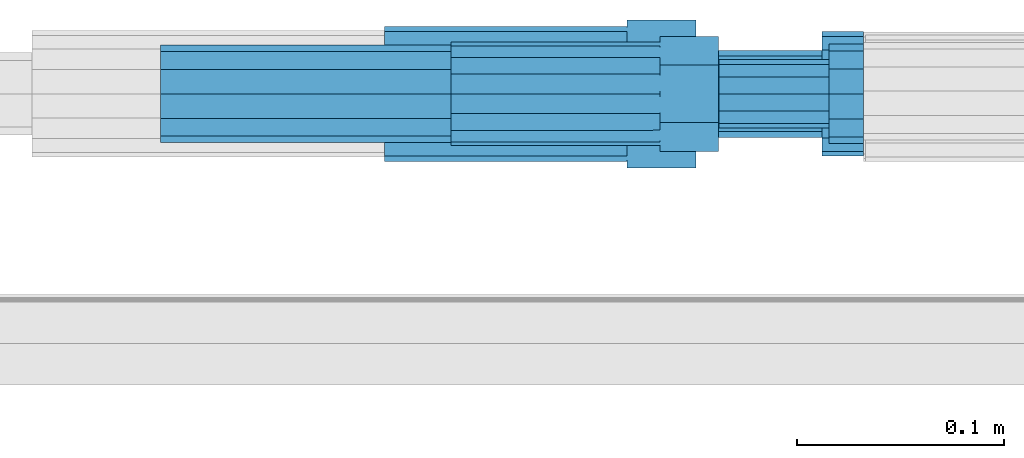
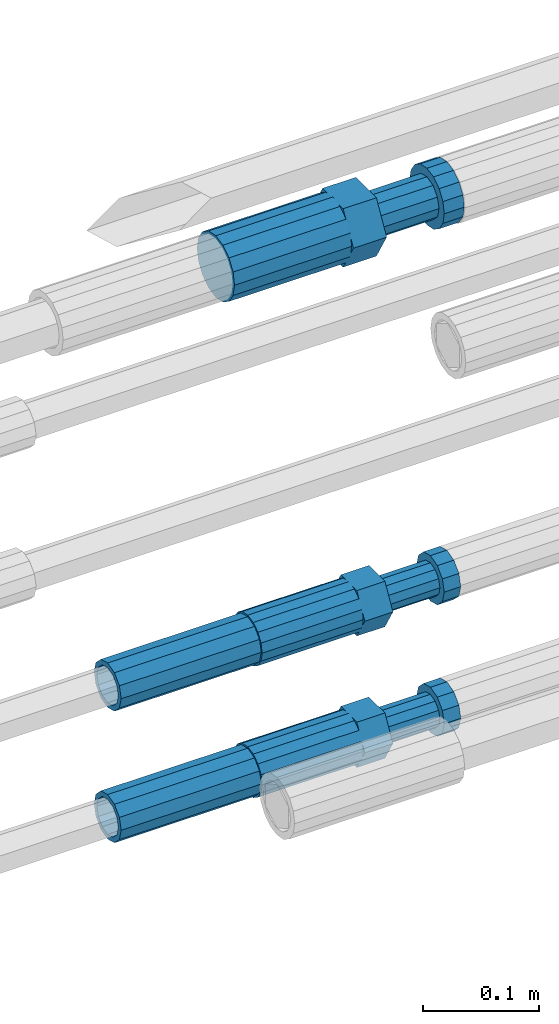
# One storey, part 7 of 119: 5 beams.
"""IFC2X3 building model written with IfcOpenShell, lengths in millimetres."""

from ifc_helpers import new_model, si_unit, frame, origin_with_axes, place, context, subcontext, project, spatial, faceted_brep, material, type_object, element, save


model = new_model("IFC2X3")

# Units and contexts
model_context = context("Model", 3, precision=1e-05, world=origin_with_axes())
body_context = subcontext(model_context, "Body", "Model", "MODEL_VIEW")
ifc_project = project(units=[si_unit("LENGTHUNIT", "METRE", prefix="MILLI"), si_unit("AREAUNIT", "SQUARE_METRE"), si_unit("VOLUMEUNIT", "CUBIC_METRE"), si_unit("MASSUNIT", "GRAM", prefix="KILO"), si_unit("TIMEUNIT", "SECOND"), si_unit("PLANEANGLEUNIT", "RADIAN"), si_unit("SOLIDANGLEUNIT", "STERADIAN"), si_unit("THERMODYNAMICTEMPERATUREUNIT", "DEGREE_CELSIUS"), si_unit("LUMINOUSINTENSITYUNIT", "LUMEN")], contexts=[model_context])

# Site, building, storey
site_placement = place(None, origin_with_axes())
site = spatial("IfcSite", under=ifc_project, at=site_placement, CompositionType="ELEMENT")
building_placement = place(site_placement, origin_with_axes())
building = spatial("IfcBuilding", under=site, at=building_placement, Name="Undefined", CompositionType="ELEMENT")
storey_placement = place(building_placement, origin_with_axes())
storey = spatial("IfcBuildingStorey", under=building, at=storey_placement, Name="Undefined", CompositionType="ELEMENT", Elevation=0.0)

# Beams
ifc_material = material(Name="STEEL/S275")
beam_type_1 = type_object("IfcBeamType", Name="ROD65", PredefinedType="NOTDEFINED")
beam_1_placement = place(storey_placement, frame((2031618.05849044, 6206402.19622016, 19414.990687125), z_axis=(0.0, 0.0, 1.0), x_axis=(1.0, 0.0, 0.0)))
element("IfcBeam", 1, at=beam_1_placement, inside=storey, type_object=beam_type_1, material=ifc_material, Name="AGB40", ObjectType="ROD65", context=body_context, shape_type="Brep", body=[
    faceted_brep([(116.999999999069, 17.8249999252148, 30.8738056446964), (116.999999998137, 22.0056957420893, 23.632628078838), (116.999999999069, 12.4372115600854, 30.0260848066173), (116.999999999069, 8.17543111252598, 30.8738056446964), (117.000000000931, -17.8250000746921, 30.8738056446964), (150.200000001118, -17.8250000723638, 30.8738056446964), (150.199999999255, 17.8249999275431, 30.8738056446964), (117.000000000931, -8.17543109622784, 30.8738056446964), (117.000000001863, -22.0056959956419, 23.6326278985034), (117.000000000931, -12.4372115437873, 30.0260848066173), (117.000000001863, -35.6500000746455, -2.18278728425503e-10), (150.200000002049, -35.6500000723172, -2.18278728425503e-10), (117.000000001863, -30.8443149488885, 8.32369080289209), (117.000000001863, -30.8443149488885, -8.32369080355784), (117.000000002794, -32.4999999918509, 0.0), (117.000000000931, -17.8250000746921, -30.873805645133), (150.200000001118, -17.8250000723638, -30.873805645133), (117.000000001863, -22.0056959961075, -23.6326278982269), (117.000000000931, -8.17543109389953, -30.873805645133), (117.000000000931, -12.4372115437873, -30.0260848066173), (116.999999999069, 17.8249999252148, -30.873805645133), (150.199999999255, 17.8249999275431, -30.873805645133), (116.999999999069, 8.17543111019768, -30.873805645133), (116.999999999069, 12.4372115600854, -30.0260848066173), (116.999999998137, 22.005695742555, -23.6326280785652), (116.999999998137, 35.6499999251682, -2.18278728425503e-10), (150.199999998324, 35.6499999277294, -2.18278728425503e-10), (116.999999998137, 30.8443150522653, -8.32369036550881), (116.999999997206, 32.5000000081491, 0.0), (116.999999998137, 30.8443150522653, 8.32369036483942), (1.86264514923096e-09, -22.9809703885112, 22.9809703885621), (1.86264514923096e-09, -30.0260848065373, 12.4372115518672), (117.000000001863, -30.0260847983882, 12.4372115518672), (117.000000001863, -22.9809703803621, 22.9809703885621), (-1.86264514923096e-09, 22.9809703885112, -22.9809703885621), (-1.86264514923096e-09, 30.0260848065373, -12.4372115518672), (116.999999998137, 30.0260848146863, -12.4372115518672), (116.999999998137, 22.9809703966603, -22.9809703885621), (1.86264514923096e-09, -30.0260848065373, -12.4372115518672), (1.86264514923096e-09, -22.9809703885112, -22.9809703885621), (117.000000001863, -22.9809703803621, -22.9809703885621), (117.000000001863, -30.0260847983882, -12.4372115518672), (9.31322574615479e-10, -12.4372115519363, 30.0260848066173), (0.0, 0.0, 32.5), (-9.31322574615479e-10, 12.4372115519363, 30.0260848066173), (-1.86264514923096e-09, 22.9809703885112, 22.9809703885621), (-1.86264514923096e-09, 30.0260848065373, 12.4372115518672), (-2.79396772384644e-09, 32.5, 0.0), (-9.31322574615479e-10, 12.4372115519363, -30.0260848066173), (0.0, 0.0, -32.5), (9.31322574615479e-10, -12.4372115519363, -30.0260848066173), (2.79396772384644e-09, -32.5, 0.0), (116.999999998137, 22.9809703966603, 22.9809703885621), (116.999999998137, 30.0260848146863, 12.4372115518672), (117.0, 8.14907252788544e-09, -32.5), (117.0, 8.14907252788544e-09, 32.5), (150.200000000186, -10.5000000959262, 18.1865334791873), (150.199999999255, -9.59262251853943e-08, 20.9999999997126), (150.199999998324, 10.4999999040738, 18.1865334791873), (150.199999997392, 18.1865333835594, 10.4999999997126), (150.199999997392, 20.9999999040738, -2.87400325760245e-10), (150.199999997392, 18.1865333835594, -10.5000000002874), (150.199999998324, 10.4999999040738, -18.1865334797621), (150.199999999255, -9.59262251853943e-08, -21.0000000002874), (150.200000000186, -10.5000000959262, -18.1865334797621), (150.200000000186, -18.1865335754119, -10.5000000002874), (150.200000001118, -21.0000000959262, -2.87400325760245e-10), (150.200000000186, -18.1865335754119, 10.4999999997126), (210.979999999516, 10.4999999082647, 18.1865334791873), (210.979999999516, -9.17352735996246e-08, 20.9999999997126), (210.979999997653, 18.1865333877504, 10.4999999997126), (210.979999997653, 20.9999999082647, -2.87400325760245e-10), (210.979999997653, 18.1865333877504, -10.5000000002874), (210.979999999516, 10.4999999082647, -18.1865334797621), (210.979999999516, -9.17352735996246e-08, -21.0000000002874), (210.979999999516, -10.5000000917353, -18.1865334797621), (210.980000000447, -18.1865335712209, -10.5000000002874), (210.980000001378, -21.0000000917353, -2.87400325760245e-10), (210.980000000447, -18.1865335712209, 10.4999999997126), (210.979999999516, -10.5000000917353, 18.1865334791873), (211.001368402503, -27.7269939335529, -11.4911163272045), (211.003082515672, -21.2238095656503, -21.2238154190527), (231.002518340945, -21.2131946226582, -21.2132004554769), (231.000804228708, -27.7163789905608, -11.4805013636287), (211.001368415542, -11.4911086384673, -27.7269970399575), (231.000804241747, -11.4804936954752, -27.7163820763781), (210.996487061493, -0.0106066407170147, -30.0106107396168), (230.995922887698, 8.30227509140968e-06, -29.999995776041), (210.98918159306, 11.4698940692469, -27.7269970332745), (230.988617419265, 11.4805090120062, -27.7163820696951), (210.980564201251, 21.2025913291145, -21.2238154067054), (230.980000027455, 21.2132062721066, -21.2132004431296), (210.971946807578, 27.7057702087332, -11.4911163110701), (230.971382633783, 27.7163851517253, -11.4805013474943), (210.964641331695, 29.9893806746695, -0.0106149565435771), (230.9640771579, 29.9999956176616, 7.03221303410828e-09), (210.959759964608, 27.7057637346443, 11.4698863966551), (230.959195790812, 27.7163786776364, 11.4805013602345), (210.958045851439, 21.2025793667417, 21.2025854885032), (230.957481677644, 21.2131943097338, 21.2132004520827), (210.959759951569, 11.4698784395587, 27.705767109408), (230.959195776843, 11.4804933823179, 27.7163820729838), (210.964641305618, -0.0106235581915826, 29.9893808090674), (230.964077131823, -8.61519947648048e-06, 29.9999957726432), (210.971946774051, -11.4911242681555, 27.7057671027251), (230.971382599324, -11.4805093251634, 27.7163820663009), (210.98056416586, -21.2238215280231, 21.2025854761559), (230.979999991134, -21.2132065852638, 21.2132004397354), (210.989181559533, -27.7270004076418, 11.4698863805206), (230.988617384806, -27.7163854646496, 11.4805013441), (210.996487035416, -30.0106108735781, -0.0106149740058754), (230.995922861621, -29.999995930586, -1.04300852399319e-08)], [[[0, 1, 2, 3]], [[4, 5, 6, 0, 3, 7]], [[8, 4, 7, 9]], [[10, 11, 5, 4, 8, 12]], [[13, 10, 12, 14]], [[15, 16, 11, 10, 13, 17]], [[18, 15, 17, 19]], [[20, 21, 16, 15, 18, 22]], [[20, 22, 23, 24]], [[25, 26, 21, 20, 24, 27]], [[25, 27, 28, 29]], [[30, 31, 32, 33]], [[34, 35, 36, 37]], [[38, 39, 40, 41]], [[31, 30, 42, 43, 44, 45, 46, 47, 35, 34, 48, 49, 50, 39, 38, 51]], [[46, 45, 52, 53]], [[28, 47, 46, 53, 29]], [[27, 36, 35, 47, 28]], [[24, 37, 36, 27]], [[23, 48, 34, 37, 24]], [[22, 54, 49, 48, 23]], [[18, 54, 22]], [[19, 50, 49, 54, 18]], [[17, 40, 39, 50, 19]], [[13, 41, 40, 17]], [[14, 51, 38, 41, 13]], [[12, 32, 31, 51, 14]], [[8, 33, 32, 12]], [[9, 42, 30, 33, 8]], [[7, 55, 43, 42, 9]], [[3, 55, 7]], [[2, 44, 43, 55, 3]], [[1, 52, 45, 44, 2]], [[29, 53, 52, 1]], [[0, 6, 26, 25, 29, 1]], [[5, 11, 16, 21, 26, 6], [56, 57, 58, 59, 60, 61, 62, 63, 64, 65, 66, 67]], [[68, 58, 57, 69]], [[70, 59, 58, 68]], [[71, 60, 59, 70]], [[72, 61, 60, 71]], [[73, 62, 61, 72]], [[74, 63, 62, 73]], [[75, 64, 63, 74]], [[76, 65, 64, 75]], [[77, 66, 65, 76]], [[78, 67, 66, 77]], [[79, 56, 67, 78]], [[69, 57, 56, 79]], [[80, 81, 82, 83]], [[81, 84, 85, 82]], [[84, 86, 87, 85]], [[86, 88, 89, 87]], [[88, 90, 91, 89]], [[90, 92, 93, 91]], [[92, 94, 95, 93]], [[94, 96, 97, 95]], [[96, 98, 99, 97]], [[98, 100, 101, 99]], [[100, 102, 103, 101]], [[102, 104, 105, 103]], [[104, 106, 107, 105]], [[106, 108, 109, 107]], [[108, 110, 111, 109]], [[82, 85, 87, 89, 91, 93, 95, 97, 99, 101, 103, 105, 107, 109, 111, 83]], [[110, 80, 83, 111]], [[108, 106, 104, 102, 100, 98, 96, 94, 92, 90, 88, 86, 84, 81, 80, 110], [78, 77, 76, 75, 74, 73, 72, 71, 70, 68, 69, 79]]]),
])
beam_type_2 = type_object("IfcBeamType", PredefinedType="NOTDEFINED")
beam_2_placement = place(storey_placement, frame((2031510.00848842, 6206402.19622982, 19010.4906861021), z_axis=(0.0, 0.0, 1.0), x_axis=(1.0, 0.0, 0.0)))
element("IfcBeam", 2, at=beam_2_placement, inside=storey, type_object=beam_type_2, material=ifc_material, Name="AG32N", context=body_context, shape_type="Brep", body=[
    faceted_brep([(1.39698386192322e-09, -18.4999999990687, 0.0), (1.16415321826935e-09, -16.0214699693024, 9.25), (140.000000001164, -16.0214699935168, 9.25), (140.000000001397, -18.5000000232831, 0.0), (6.98491930961609e-10, -9.24999999906868, 16.0214699700118), (140.000000000698, -9.25000002328306, 16.0214699700118), (2.3283064365387e-10, 9.31322574615479e-10, 18.5), (140.000000000233, -2.3283064365387e-08, 18.5), (-2.3283064365387e-10, 9.25000000093132, 16.0214699700118), (139.999999999767, 9.24999997671694, 16.0214699700118), (-6.98491930961609e-10, 16.0214699711651, 9.25), (139.999999999302, 16.0214699469507, 9.25), (-9.31322574615479e-10, 18.5000000009313, 0.0), (139.999999999069, 18.4999999767169, 0.0), (-6.98491930961609e-10, 16.0214699711651, -9.25), (139.999999999302, 16.0214699469507, -9.25), (-2.3283064365387e-10, 9.25000000093132, -16.0214699700118), (139.999999999767, 9.24999997671694, -16.0214699700118), (2.3283064365387e-10, 9.31322574615479e-10, -18.5), (140.000000000233, -2.3283064365387e-08, -18.5), (6.98491930961609e-10, -9.24999999906868, -16.0214699700118), (140.000000000698, -9.25000002328306, -16.0214699700118), (1.16415321826935e-09, -16.0214699693024, -9.25), (140.000000001164, -16.0214699935168, -9.25), (1.62981450557709e-09, -23.4999999990687, 0.0), (1.39698386192322e-09, -20.3515969878063, -11.75), (140.000000001397, -20.3515970120206, -11.75), (140.00000000163, -23.5000000232831, 0.0), (9.31322574615479e-10, -11.7499999990687, -20.351596988934), (140.000000000931, -11.7500000232831, -20.351596988934), (2.3283064365387e-10, 9.31322574615479e-10, -23.5), (140.000000000233, -2.3283064365387e-08, -23.5), (-4.65661287307739e-10, 11.7500000009313, -20.351596988934), (139.999999999534, 11.7499999767169, -20.351596988934), (-9.31322574615479e-10, 20.3515969896689, -11.75), (139.999999999069, 20.3515969654545, -11.75), (-1.16415321826935e-09, 23.5000000009313, 0.0), (139.999999998836, 23.4999999767169, 0.0), (-9.31322574615479e-10, 20.3515969896689, 11.75), (139.999999999069, 20.3515969654545, 11.75), (-4.65661287307739e-10, 11.7500000009313, 20.351596988934), (139.999999999534, 11.7499999767169, 20.351596988934), (2.3283064365387e-10, 9.31322574615479e-10, 23.5), (140.000000000233, -2.3283064365387e-08, 23.5), (9.31322574615479e-10, -11.7499999990687, 20.351596988934), (140.000000000931, -11.7500000232831, 20.351596988934), (1.39698386192322e-09, -20.3515969878063, 11.75), (140.000000001397, -20.3515970120206, 11.75)], [[[0, 1, 2, 3]], [[1, 4, 5, 2]], [[4, 6, 7, 5]], [[6, 8, 9, 7]], [[8, 10, 11, 9]], [[10, 12, 13, 11]], [[12, 14, 15, 13]], [[14, 16, 17, 15]], [[16, 18, 19, 17]], [[18, 20, 21, 19]], [[20, 22, 23, 21]], [[22, 0, 3, 23]], [[24, 25, 26, 27]], [[25, 28, 29, 26]], [[28, 30, 31, 29]], [[30, 32, 33, 31]], [[32, 34, 35, 33]], [[34, 36, 37, 35]], [[36, 38, 39, 37]], [[38, 40, 41, 39]], [[40, 42, 43, 41]], [[42, 44, 45, 43]], [[44, 46, 47, 45]], [[46, 24, 27, 47]], [[29, 31, 33, 35, 37, 39, 41, 43, 45, 47, 27, 26], [5, 7, 9, 11, 13, 15, 17, 19, 21, 23, 3, 2]], [[46, 44, 42, 40, 38, 36, 34, 32, 30, 28, 25, 24], [22, 20, 18, 16, 14, 12, 10, 8, 6, 4, 1, 0]]]),
])
beam_3_placement = place(storey_placement, frame((2031510.00848842, 6206402.19622982, 18871.4906861021), z_axis=(0.0, 0.0, 1.0), x_axis=(1.0, 0.0, 0.0)))
element("IfcBeam", 3, at=beam_3_placement, inside=storey, type_object=beam_type_2, material=ifc_material, Name="AG32N", context=body_context, shape_type="Brep", body=[
    faceted_brep([(1.39698386192322e-09, -18.4999999990687, 0.0), (1.16415321826935e-09, -16.0214699693024, 9.25), (140.000000001164, -16.0214699935168, 9.25), (140.000000001397, -18.5000000232831, 0.0), (6.98491930961609e-10, -9.24999999906868, 16.0214699700118), (140.000000000698, -9.25000002328306, 16.0214699700118), (2.3283064365387e-10, 9.31322574615479e-10, 18.5), (140.000000000233, -2.3283064365387e-08, 18.5), (-2.3283064365387e-10, 9.25000000093132, 16.0214699700118), (139.999999999767, 9.24999997671694, 16.0214699700118), (-6.98491930961609e-10, 16.0214699711651, 9.25), (139.999999999302, 16.0214699469507, 9.25), (-9.31322574615479e-10, 18.5000000009313, 0.0), (139.999999999069, 18.4999999767169, 0.0), (-6.98491930961609e-10, 16.0214699711651, -9.25), (139.999999999302, 16.0214699469507, -9.25), (-2.3283064365387e-10, 9.25000000093132, -16.0214699700118), (139.999999999767, 9.24999997671694, -16.0214699700118), (2.3283064365387e-10, 9.31322574615479e-10, -18.5), (140.000000000233, -2.3283064365387e-08, -18.5), (6.98491930961609e-10, -9.24999999906868, -16.0214699700118), (140.000000000698, -9.25000002328306, -16.0214699700118), (1.16415321826935e-09, -16.0214699693024, -9.25), (140.000000001164, -16.0214699935168, -9.25), (1.62981450557709e-09, -23.4999999990687, 0.0), (1.39698386192322e-09, -20.3515969878063, -11.75), (140.000000001397, -20.3515970120206, -11.75), (140.00000000163, -23.5000000232831, 0.0), (9.31322574615479e-10, -11.7499999990687, -20.351596988934), (140.000000000931, -11.7500000232831, -20.351596988934), (2.3283064365387e-10, 9.31322574615479e-10, -23.5), (140.000000000233, -2.3283064365387e-08, -23.5), (-4.65661287307739e-10, 11.7500000009313, -20.351596988934), (139.999999999534, 11.7499999767169, -20.351596988934), (-9.31322574615479e-10, 20.3515969896689, -11.75), (139.999999999069, 20.3515969654545, -11.75), (-1.16415321826935e-09, 23.5000000009313, 0.0), (139.999999998836, 23.4999999767169, 0.0), (-9.31322574615479e-10, 20.3515969896689, 11.75), (139.999999999069, 20.3515969654545, 11.75), (-4.65661287307739e-10, 11.7500000009313, 20.351596988934), (139.999999999534, 11.7499999767169, 20.351596988934), (2.3283064365387e-10, 9.31322574615479e-10, 23.5), (140.000000000233, -2.3283064365387e-08, 23.5), (9.31322574615479e-10, -11.7499999990687, 20.351596988934), (140.000000000931, -11.7500000232831, 20.351596988934), (1.39698386192322e-09, -20.3515969878063, 11.75), (140.000000001397, -20.3515970120206, 11.75)], [[[0, 1, 2, 3]], [[1, 4, 5, 2]], [[4, 6, 7, 5]], [[6, 8, 9, 7]], [[8, 10, 11, 9]], [[10, 12, 13, 11]], [[12, 14, 15, 13]], [[14, 16, 17, 15]], [[16, 18, 19, 17]], [[18, 20, 21, 19]], [[20, 22, 23, 21]], [[22, 0, 3, 23]], [[24, 25, 26, 27]], [[25, 28, 29, 26]], [[28, 30, 31, 29]], [[30, 32, 33, 31]], [[32, 34, 35, 33]], [[34, 36, 37, 35]], [[36, 38, 39, 37]], [[38, 40, 41, 39]], [[40, 42, 43, 41]], [[42, 44, 45, 43]], [[44, 46, 47, 45]], [[46, 24, 27, 47]], [[29, 31, 33, 35, 37, 39, 41, 43, 45, 47, 27, 26], [5, 7, 9, 11, 13, 15, 17, 19, 21, 23, 3, 2]], [[46, 44, 42, 40, 38, 36, 34, 32, 30, 28, 25, 24], [22, 20, 18, 16, 14, 12, 10, 8, 6, 4, 1, 0]]]),
])
beam_type_3 = type_object("IfcBeamType", Name="ROD50", PredefinedType="NOTDEFINED")
beam_4_placement = place(storey_placement, frame((2031650.00848842, 6206402.19622658, 19010.490686162), z_axis=(0.0, 0.0, 1.0), x_axis=(1.0, 0.0, 0.0)))
element("IfcBeam", 4, at=beam_4_placement, inside=storey, type_object=beam_type_3, material=ifc_material, Name="AGB32", ObjectType="ROD50", context=body_context, shape_type="Brep", body=[
    faceted_brep([(100.999999995111, 13.8425000002608, 23.9759132212093), (100.999999996508, 17.5285119004548, 17.5915533324223), (100.999999997672, 9.56708580907434, 23.0969883129546), (100.999999995111, 5.14843190740794, 23.9759132212093), (100.999999995111, -13.8425000002608, 23.9759132212093), (129.099999995669, -13.8425000002608, 23.9759132182917), (129.099999995669, 13.8425000002608, 23.9759132182917), (100.999999995111, -5.14843190740794, 23.9759132212093), (100.999999996508, -17.5285119004548, 17.5915533324223), (100.999999997672, -9.56708580907434, 23.0969883129546), (101.000000000233, -27.6849999995902, -8.25639290269464e-08), (129.100000000792, -27.6849999995902, -8.5481588030234e-08), (100.999999998836, -23.5887256683782, 7.09495518143376), (101.00000000163, -23.5887256180868, -7.09495543353478), (101.000000000233, -25.0, 1.70985003933311e-10), (101.000000005355, -13.8425000002608, -23.9759133863372), (129.100000005914, -13.8425000002608, -23.9759133892549), (101.000000003958, -17.5285119721666, -17.5915533734478), (101.000000005355, -5.14843107573688, -23.9759133863372), (101.000000002561, -9.56708580907434, -23.0969883126127), (101.000000005355, 13.8425000002608, -23.9759133863372), (129.100000005914, 13.8425000002608, -23.9759133892549), (101.000000005355, 5.14843107573688, -23.9759133863372), (101.000000002561, 9.56708580907434, -23.0969883126127), (101.000000003958, 17.5285119721666, -17.5915533734478), (101.000000000233, 27.6849999995902, -8.25639290269464e-08), (129.100000000792, 27.6849999995902, -8.5481588030234e-08), (101.00000000163, 23.5887256180868, -7.09495543353478), (101.000000000233, 25.0, 1.70985003933311e-10), (100.999999998836, 23.5887256683782, 7.09495518143376), (-6.98491930961609e-10, -23.0969883129001, 9.56708580912891), (-1.62981450557709e-09, -17.6776695298031, 17.6776695296649), (-2.3283064365387e-09, -9.56708580907434, 23.0969883127837), (-2.56113708019257e-09, 0.0, 25.0), (-2.3283064365387e-09, 9.56708580907434, 23.0969883127837), (-1.62981450557709e-09, 17.6776695298031, 17.6776695296649), (-6.98491930961609e-10, 23.0969883129001, 9.56708580912891), (2.3283064365387e-10, 25.0, 0.0), (1.16415321826935e-09, 23.0969883129001, -9.56708580912891), (2.09547579288483e-09, 17.6776695298031, -17.6776695296649), (2.56113708019257e-09, 9.56708580907434, -23.0969883127837), (2.79396772384644e-09, 0.0, -25.0), (2.56113708019257e-09, -9.56708580907434, -23.0969883127837), (2.09547579288483e-09, -17.6776695298031, -17.6776695296649), (1.16415321826935e-09, -23.0969883129001, -9.56708580912891), (2.3283064365387e-10, -25.0, 0.0), (100.999999999302, 23.0969883129001, 9.5670858092999), (101.000000001164, 23.0969883129001, -9.56708580895793), (101.000000002794, 0.0, -24.999999999829), (101.000000001164, -23.0969883129001, -9.56708580895793), (100.999999999302, -23.0969883129001, 9.5670858092999), (100.999999997439, 0.0, 25.000000000171), (129.49999999837, -14.2894191620871, 8.24999989414209), (129.499999996973, -8.25, 14.2894190565821), (129.49999999674, 0.0, 16.4999998941421), (129.499999996973, 8.25, 14.2894190565821), (129.49999999837, 14.2894191620871, 8.24999989414209), (129.500000000233, 16.5, -1.05857907328755e-07), (129.500000002095, 14.2894191620871, -8.25000010585791), (129.50000000326, 8.25, -14.2894192683016), (129.500000003492, 0.0, -16.5000001058615), (129.50000000326, -8.25, -14.2894192683016), (129.500000002095, -14.2894191620871, -8.25000010586155), (129.500000000233, -16.5, -1.05857907328755e-07), (182.499999996973, 8.25, 14.2894190510815), (182.49999999674, 0.0, 16.4999998886415), (182.49999999837, 14.2894191620871, 8.24999988864147), (182.500000000233, 16.5, -1.11358531285077e-07), (182.500000002095, 14.2894191620871, -8.25000011135853), (182.50000000326, 8.25, -14.2894192738022), (182.500000003492, 0.0, -16.5000001113622), (182.50000000326, -8.25, -14.2894192738022), (182.500000002095, -14.2894191620871, -8.25000011136217), (182.500000000233, -16.5, -1.11358531285077e-07), (182.49999999837, -14.2894191620871, 8.24999988864147), (182.499999996973, -8.25, 14.2894190510815), (182.500000002561, -20.7846096912399, -12.0000001491826), (182.500000004657, -12.0, -20.7846098400078), (199.000000004657, -12.0, -20.7846098417212), (199.000000002561, -20.7846096912399, -12.0000001508961), (182.500000005355, 0.0, -24.0000001491826), (199.000000005355, 0.0, -24.0000001508961), (182.500000004657, 12.0, -20.7846098400078), (199.000000004657, 12.0, -20.7846098417212), (182.500000002561, 20.7846096912399, -12.000000149179), (199.000000002561, 20.7846096912399, -12.0000001508924), (182.500000000233, 24.0, -1.49178958963603e-07), (199.000000000233, 24.0, -1.50892446981743e-07), (182.499999997672, 20.7846096912399, 11.999999850821), (198.999999997672, 20.7846096912399, 11.9999998491076), (182.499999995809, 12.0, 20.7846095416462), (198.999999995809, 12.0, 20.7846095399327), (182.499999995111, 0.0, 23.999999850821), (198.999999995111, 0.0, 23.9999998491076), (182.499999995809, -12.0, 20.7846095416462), (198.999999995809, -12.0, 20.7846095399327), (182.499999997672, -20.7846096912399, 11.999999850821), (198.999999997672, -20.7846096912399, 11.9999998491039), (182.500000000233, -24.0, -1.49178958963603e-07), (199.000000000233, -24.0, -1.50892446981743e-07)], [[[0, 1, 2, 3]], [[4, 5, 6, 0, 3, 7]], [[8, 4, 7, 9]], [[10, 11, 5, 4, 8, 12]], [[13, 10, 12, 14]], [[15, 16, 11, 10, 13, 17]], [[18, 15, 17, 19]], [[20, 21, 16, 15, 18, 22]], [[20, 22, 23, 24]], [[25, 26, 21, 20, 24, 27]], [[25, 27, 28, 29]], [[30, 31, 32, 33, 34, 35, 36, 37, 38, 39, 40, 41, 42, 43, 44, 45]], [[28, 37, 36, 46, 29]], [[27, 47, 38, 37, 28]], [[24, 47, 27]], [[39, 38, 47, 24]], [[23, 40, 39, 24]], [[22, 48, 41, 40, 23]], [[18, 48, 22]], [[19, 42, 41, 48, 18]], [[17, 43, 42, 19]], [[44, 43, 17, 49]], [[13, 49, 17]], [[14, 45, 44, 49, 13]], [[12, 50, 30, 45, 14]], [[8, 50, 12]], [[31, 30, 50, 8]], [[9, 32, 31, 8]], [[7, 51, 33, 32, 9]], [[3, 51, 7]], [[2, 34, 33, 51, 3]], [[1, 35, 34, 2]], [[36, 35, 1, 46]], [[29, 46, 1]], [[0, 6, 26, 25, 29, 1]], [[5, 11, 16, 21, 26, 6]], [[52, 53, 54, 55, 56, 57, 58, 59, 60, 61, 62, 63]], [[64, 55, 54, 65]], [[66, 56, 55, 64]], [[67, 57, 56, 66]], [[68, 58, 57, 67]], [[69, 59, 58, 68]], [[70, 60, 59, 69]], [[71, 61, 60, 70]], [[72, 62, 61, 71]], [[73, 63, 62, 72]], [[74, 52, 63, 73]], [[75, 53, 52, 74]], [[65, 54, 53, 75]], [[76, 77, 78, 79]], [[77, 80, 81, 78]], [[80, 82, 83, 81]], [[82, 84, 85, 83]], [[84, 86, 87, 85]], [[86, 88, 89, 87]], [[88, 90, 91, 89]], [[90, 92, 93, 91]], [[92, 94, 95, 93]], [[94, 96, 97, 95]], [[96, 98, 99, 97]], [[78, 81, 83, 85, 87, 89, 91, 93, 95, 97, 99, 79]], [[98, 76, 79, 99]], [[96, 94, 92, 90, 88, 86, 84, 82, 80, 77, 76, 98], [74, 73, 72, 71, 70, 69, 68, 67, 66, 64, 65, 75]]]),
])
beam_5_placement = place(storey_placement, frame((2031650.00848842, 6206402.19622658, 18871.490686162), z_axis=(0.0, 0.0, 1.0), x_axis=(1.0, 0.0, 0.0)))
element("IfcBeam", 5, at=beam_5_placement, inside=storey, type_object=beam_type_3, material=ifc_material, Name="AGB32", ObjectType="ROD50", context=body_context, shape_type="Brep", body=[
    faceted_brep([(100.999999995111, 13.8425000002608, 23.9759132212093), (100.999999996508, 17.5285119004548, 17.5915533324223), (100.999999997672, 9.56708580907434, 23.0969883129546), (100.999999995111, 5.14843190740794, 23.9759132212093), (100.999999995111, -13.8425000002608, 23.9759132212093), (129.099999995669, -13.8425000002608, 23.9759132182917), (129.099999995669, 13.8425000002608, 23.9759132182917), (100.999999995111, -5.14843190740794, 23.9759132212093), (100.999999996508, -17.5285119004548, 17.5915533324223), (100.999999997672, -9.56708580907434, 23.0969883129546), (101.000000000233, -27.6849999995902, -8.25639290269464e-08), (129.100000000792, -27.6849999995902, -8.5481588030234e-08), (100.999999998836, -23.5887256683782, 7.09495518143376), (101.00000000163, -23.5887256180868, -7.09495543353478), (101.000000000233, -25.0, 1.70985003933311e-10), (101.000000005355, -13.8425000002608, -23.9759133863372), (129.100000005914, -13.8425000002608, -23.9759133892549), (101.000000003958, -17.5285119721666, -17.5915533734478), (101.000000005355, -5.14843107573688, -23.9759133863372), (101.000000002561, -9.56708580907434, -23.0969883126127), (101.000000005355, 13.8425000002608, -23.9759133863372), (129.100000005914, 13.8425000002608, -23.9759133892549), (101.000000005355, 5.14843107573688, -23.9759133863372), (101.000000002561, 9.56708580907434, -23.0969883126127), (101.000000003958, 17.5285119721666, -17.5915533734478), (101.000000000233, 27.6849999995902, -8.25639290269464e-08), (129.100000000792, 27.6849999995902, -8.5481588030234e-08), (101.00000000163, 23.5887256180868, -7.09495543353478), (101.000000000233, 25.0, 1.70985003933311e-10), (100.999999998836, 23.5887256683782, 7.09495518143376), (-6.98491930961609e-10, -23.0969883129001, 9.56708580912891), (-1.62981450557709e-09, -17.6776695298031, 17.6776695296649), (-2.3283064365387e-09, -9.56708580907434, 23.0969883127837), (-2.56113708019257e-09, 0.0, 25.0), (-2.3283064365387e-09, 9.56708580907434, 23.0969883127837), (-1.62981450557709e-09, 17.6776695298031, 17.6776695296649), (-6.98491930961609e-10, 23.0969883129001, 9.56708580912891), (2.3283064365387e-10, 25.0, 0.0), (1.16415321826935e-09, 23.0969883129001, -9.56708580912891), (2.09547579288483e-09, 17.6776695298031, -17.6776695296649), (2.56113708019257e-09, 9.56708580907434, -23.0969883127837), (2.79396772384644e-09, 0.0, -25.0), (2.56113708019257e-09, -9.56708580907434, -23.0969883127837), (2.09547579288483e-09, -17.6776695298031, -17.6776695296649), (1.16415321826935e-09, -23.0969883129001, -9.56708580912891), (2.3283064365387e-10, -25.0, 0.0), (100.999999999302, 23.0969883129001, 9.5670858092999), (101.000000001164, 23.0969883129001, -9.56708580895793), (101.000000002794, 0.0, -24.999999999829), (101.000000001164, -23.0969883129001, -9.56708580895793), (100.999999999302, -23.0969883129001, 9.5670858092999), (100.999999997439, 0.0, 25.000000000171), (129.49999999837, -14.2894191620871, 8.24999989414209), (129.499999996973, -8.25, 14.2894190565821), (129.49999999674, 0.0, 16.4999998941421), (129.499999996973, 8.25, 14.2894190565821), (129.49999999837, 14.2894191620871, 8.24999989414209), (129.500000000233, 16.5, -1.05857907328755e-07), (129.500000002095, 14.2894191620871, -8.25000010585791), (129.50000000326, 8.25, -14.2894192683016), (129.500000003492, 0.0, -16.5000001058615), (129.50000000326, -8.25, -14.2894192683016), (129.500000002095, -14.2894191620871, -8.25000010586155), (129.500000000233, -16.5, -1.05857907328755e-07), (182.499999996973, 8.25, 14.2894190510815), (182.49999999674, 0.0, 16.4999998886415), (182.49999999837, 14.2894191620871, 8.24999988864147), (182.500000000233, 16.5, -1.11358531285077e-07), (182.500000002095, 14.2894191620871, -8.25000011135853), (182.50000000326, 8.25, -14.2894192738022), (182.500000003492, 0.0, -16.5000001113622), (182.50000000326, -8.25, -14.2894192738022), (182.500000002095, -14.2894191620871, -8.25000011136217), (182.500000000233, -16.5, -1.11358531285077e-07), (182.49999999837, -14.2894191620871, 8.24999988864147), (182.499999996973, -8.25, 14.2894190510815), (182.500000002561, -20.7846096912399, -12.0000001491826), (182.500000004657, -12.0, -20.7846098400078), (199.000000004657, -12.0, -20.7846098417212), (199.000000002561, -20.7846096912399, -12.0000001508961), (182.500000005355, 0.0, -24.0000001491826), (199.000000005355, 0.0, -24.0000001508961), (182.500000004657, 12.0, -20.7846098400078), (199.000000004657, 12.0, -20.7846098417212), (182.500000002561, 20.7846096912399, -12.000000149179), (199.000000002561, 20.7846096912399, -12.0000001508924), (182.500000000233, 24.0, -1.49178958963603e-07), (199.000000000233, 24.0, -1.50892446981743e-07), (182.499999997672, 20.7846096912399, 11.999999850821), (198.999999997672, 20.7846096912399, 11.9999998491076), (182.499999995809, 12.0, 20.7846095416462), (198.999999995809, 12.0, 20.7846095399327), (182.499999995111, 0.0, 23.999999850821), (198.999999995111, 0.0, 23.9999998491076), (182.499999995809, -12.0, 20.7846095416462), (198.999999995809, -12.0, 20.7846095399327), (182.499999997672, -20.7846096912399, 11.999999850821), (198.999999997672, -20.7846096912399, 11.9999998491039), (182.500000000233, -24.0, -1.49178958963603e-07), (199.000000000233, -24.0, -1.50892446981743e-07)], [[[0, 1, 2, 3]], [[4, 5, 6, 0, 3, 7]], [[8, 4, 7, 9]], [[10, 11, 5, 4, 8, 12]], [[13, 10, 12, 14]], [[15, 16, 11, 10, 13, 17]], [[18, 15, 17, 19]], [[20, 21, 16, 15, 18, 22]], [[20, 22, 23, 24]], [[25, 26, 21, 20, 24, 27]], [[25, 27, 28, 29]], [[30, 31, 32, 33, 34, 35, 36, 37, 38, 39, 40, 41, 42, 43, 44, 45]], [[28, 37, 36, 46, 29]], [[27, 47, 38, 37, 28]], [[24, 47, 27]], [[39, 38, 47, 24]], [[23, 40, 39, 24]], [[22, 48, 41, 40, 23]], [[18, 48, 22]], [[19, 42, 41, 48, 18]], [[17, 43, 42, 19]], [[44, 43, 17, 49]], [[13, 49, 17]], [[14, 45, 44, 49, 13]], [[12, 50, 30, 45, 14]], [[8, 50, 12]], [[31, 30, 50, 8]], [[9, 32, 31, 8]], [[7, 51, 33, 32, 9]], [[3, 51, 7]], [[2, 34, 33, 51, 3]], [[1, 35, 34, 2]], [[36, 35, 1, 46]], [[29, 46, 1]], [[0, 6, 26, 25, 29, 1]], [[5, 11, 16, 21, 26, 6]], [[52, 53, 54, 55, 56, 57, 58, 59, 60, 61, 62, 63]], [[64, 55, 54, 65]], [[66, 56, 55, 64]], [[67, 57, 56, 66]], [[68, 58, 57, 67]], [[69, 59, 58, 68]], [[70, 60, 59, 69]], [[71, 61, 60, 70]], [[72, 62, 61, 71]], [[73, 63, 62, 72]], [[74, 52, 63, 73]], [[75, 53, 52, 74]], [[65, 54, 53, 75]], [[76, 77, 78, 79]], [[77, 80, 81, 78]], [[80, 82, 83, 81]], [[82, 84, 85, 83]], [[84, 86, 87, 85]], [[86, 88, 89, 87]], [[88, 90, 91, 89]], [[90, 92, 93, 91]], [[92, 94, 95, 93]], [[94, 96, 97, 95]], [[96, 98, 99, 97]], [[78, 81, 83, 85, 87, 89, 91, 93, 95, 97, 99, 79]], [[98, 76, 79, 99]], [[96, 94, 92, 90, 88, 86, 84, 82, 80, 77, 76, 98], [74, 73, 72, 71, 70, 69, 68, 67, 66, 64, 65, 75]]]),
])

save(model, "model.ifc")
